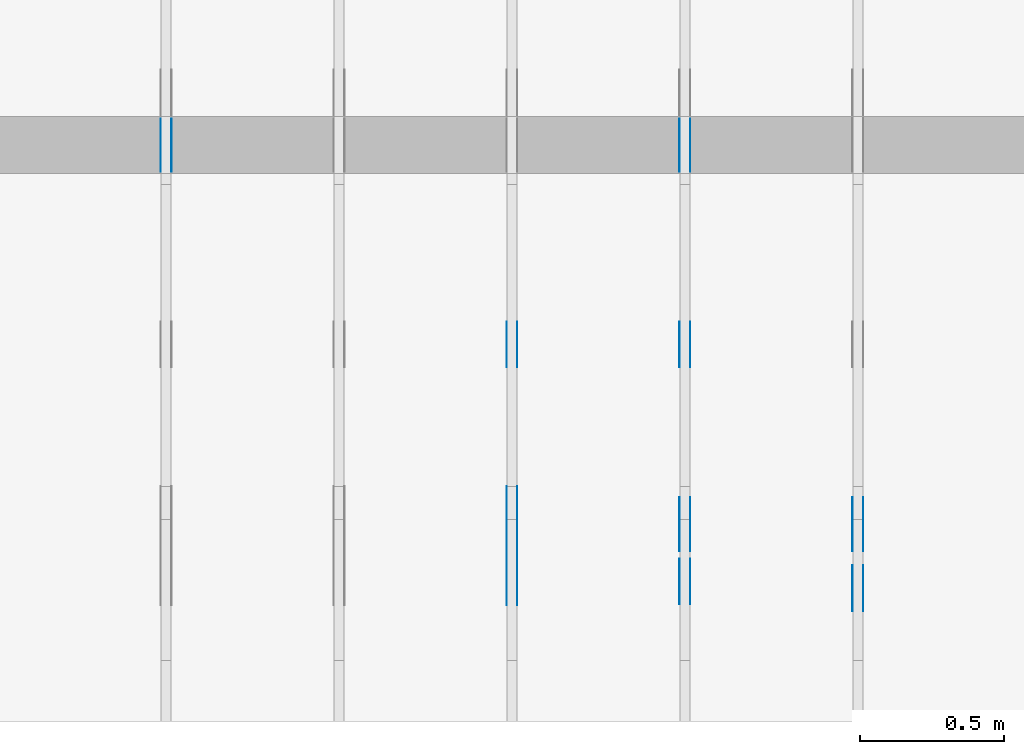
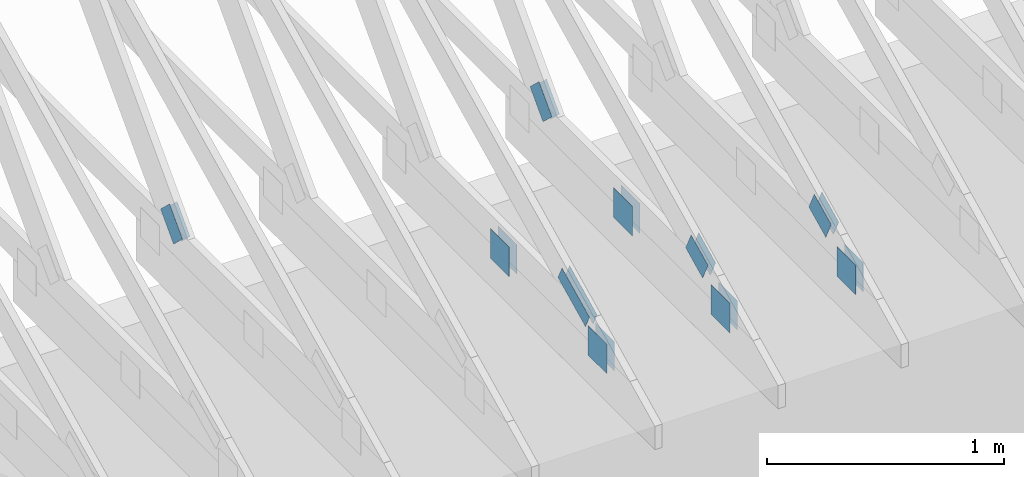
# One storey, part 74 of 159: 20 plates, 4 elements without a shape of their own.
"""IFC2X3 building model written with IfcOpenShell, lengths in millimetres."""

from ifc_helpers import new_model, si_unit, frame, origin, origin_with_axes, origin_2d, place, context, project, spatial, faceted_brep, element, aggregate, save


model = new_model("IFC2X3")

# Units and contexts
model_context = context("Model", 3, precision=1e-05, world=origin())
plan_context = context("Plan", 2, precision=1e-05, world=origin_2d())
ifc_project = project(units=[si_unit("LENGTHUNIT", "METRE", prefix="MILLI"), si_unit("AREAUNIT", "SQUARE_METRE"), si_unit("VOLUMEUNIT", "CUBIC_METRE"), si_unit("SOLIDANGLEUNIT", "STERADIAN"), si_unit("PLANEANGLEUNIT", "RADIAN"), si_unit("MASSUNIT", "GRAM"), si_unit("TIMEUNIT", "SECOND"), si_unit("THERMODYNAMICTEMPERATUREUNIT", "DEGREE_CELSIUS"), si_unit("LUMINOUSINTENSITYUNIT", "LUMEN")], contexts=[model_context, plan_context])

# Site, building, storey
site_placement = place(None, origin_with_axes())
site = spatial("IfcSite", under=ifc_project, at=site_placement, CompositionType="ELEMENT")
building_placement = place(site_placement, origin_with_axes())
building = spatial("IfcBuilding", under=site, at=building_placement, Name="Plan 1", CompositionType="ELEMENT")
storey_placement = place(building_placement, origin_with_axes())
storey = spatial("IfcBuildingStorey", under=building, at=storey_placement, Name="Etasje 1", CompositionType="ELEMENT", Elevation=0.0)

# Assembly, plates
assembly_1_placement = place(storey_placement, frame((10875.02226140475, -699.9989301294845, 1.1021457184401395e-15), z_axis=(-1.0, 1.836909530733566e-16, 6.123031769111886e-17), x_axis=(-1.836909530733566e-16, -1.0, 0.0)))
assembly_1 = element("IfcElementAssembly", 1, at=assembly_1_placement, inside=storey, Name="T4 (96)", AssemblyPlace="FACTORY", PredefinedType="TRUSS")
plate_1_placement = place(assembly_1_placement, frame((-589.402753917706, 382.43738721467554, 0.0), z_axis=(0.0, 0.0, 1.0), x_axis=(-0.898794046299167, 0.4383711467890773, 0.0)))
plate_1 = element("IfcPlate", 2, at=plate_1_placement, Name="GNT100S 103x159", context=model_context, shape_type="Brep", body=[
    faceted_brep([(159.00002333806833, 103.0000025629542, 1.0), (1.0586713528937253e-05, 103.0000025629542, 1.0), (1.127968232594867e-05, 1.5831964333301585e-05, 1.0), (159.00002403103713, 1.5831964333301585e-05, 1.0), (1.0586713528937253e-05, 103.0000025629542, 1.2964556653633881e-21), (159.00002333806833, 103.0000025629542, 1.9471243883770476e-14), (159.00002403103713, 1.4321251114779443e-05, 1.9471243968631875e-14), (1.127968232594867e-05, 1.4321251114779443e-05, 1.3813170645454712e-21), (159.0000000000001, -2.9206861538663717e-14, 5.268886006269513e-30), (159.0000000000001, -2.91456312209726e-14, 1.0), (1.1247455413666031e-32, 6.123031769111886e-17, 1.0), (0.0, 0.0, 0.0), (159.0000000000001, 103.00000000000006, 6.310887241768095e-30), (159.0000000000001, 103.00000000000006, 1.0), (159.0000000000001, 5.684341886080802e-14, 1.0), (159.0000000000001, 5.684341886080802e-14, 0.0), (0.0, 103.0, 0.0), (0.0, 103.0, 1.0), (159.0, 103.00000000000006, 1.0), (159.0, 103.00000000000006, 7.888609052210118e-31), (0.0, 0.0, 0.0), (6.123031769111886e-17, -7.498303609110687e-33, 1.0), (1.2674675762061605e-14, 103.0, 1.0), (1.2613445444370486e-14, 103.0, -7.723252717384008e-31)], [[[0, 1, 2, 3]], [[4, 5, 6, 7]], [[8, 9, 10, 11]], [[12, 13, 14, 15]], [[16, 17, 18, 19]], [[20, 21, 22, 23]]]),
])
plate_2_placement = place(assembly_1_placement, frame((-589.402753917706, 382.43738721467554, -37.0), z_axis=(0.0, 0.0, 1.0), x_axis=(-0.898794046299167, 0.4383711467890773, 0.0)))
plate_2 = element("IfcPlate", 3, at=plate_2_placement, Name="GNT100S 103x159", context=model_context, shape_type="Brep", body=[
    faceted_brep([(159.00002333806833, 103.0000025629542, 1.0), (1.0586713528937253e-05, 103.0000025629542, 1.0), (1.127968232594867e-05, 1.5831964333301585e-05, 1.0), (159.00002403103713, 1.5831964333301585e-05, 1.0), (1.0586713528937253e-05, 103.0000025629542, 1.2964556653633881e-21), (159.00002333806833, 103.0000025629542, 1.9471243883770476e-14), (159.00002403103713, 1.4321251114779443e-05, 1.9471243968631875e-14), (1.127968232594867e-05, 1.4321251114779443e-05, 1.3813170645454712e-21), (159.0000000000001, -2.9206861538663717e-14, 5.268886006269513e-30), (159.0000000000001, -2.91456312209726e-14, 1.0), (1.1247455413666031e-32, 6.123031769111886e-17, 1.0), (0.0, 0.0, 0.0), (159.0000000000001, 103.00000000000006, 6.310887241768095e-30), (159.0000000000001, 103.00000000000006, 1.0), (159.0000000000001, 5.684341886080802e-14, 1.0), (159.0000000000001, 5.684341886080802e-14, 0.0), (0.0, 103.0, 0.0), (0.0, 103.0, 1.0), (159.0, 103.00000000000006, 1.0), (159.0, 103.00000000000006, 7.888609052210118e-31), (0.0, 0.0, 0.0), (6.123031769111886e-17, -7.498303609110687e-33, 1.0), (1.2674675762061605e-14, 103.0, 1.0), (1.2613445444370486e-14, 103.0, -7.723252717384008e-31)], [[[0, 1, 2, 3]], [[4, 5, 6, 7]], [[8, 9, 10, 11]], [[12, 13, 14, 15]], [[16, 17, 18, 19]], [[20, 21, 22, 23]]]),
])
plate_3_placement = place(assembly_1_placement, frame((-382.4755138126829, 299.0, 0.0), z_axis=(0.0, 0.0, 1.0), x_axis=(-1.0, 1.2246063538223773e-16, 0.0)))
plate_3 = element("IfcPlate", 4, at=plate_3_placement, Name="GNT100S 152x159", context=model_context, shape_type="Brep", body=[
    faceted_brep([(159.0000110896608, 152.0, 1.0), (1.1089660802099388e-05, 152.0, 1.0), (1.1089660858942807e-05, 0.0, 1.0), (159.0000110896608, 0.0, 1.0), (1.1089660802099388e-05, 152.0, 1.3580469079985871e-21), (159.0000110896608, 152.0, 1.9471242383822708e-14), (159.0000110896608, 0.0, 1.9471242383822708e-14), (1.1089660858942807e-05, 0.0, 1.3580469149596683e-21), (159.0, 8.447997618295233e-14, 1.788345410772899e-30), (159.0, 8.454120650064345e-14, 1.0), (5.684341886080802e-14, 1.1374806803930715e-13, 1.0), (5.684341886080802e-14, 1.1368683772161602e-13, 0.0), (159.0, 152.0000000000001, 0.0), (159.0, 152.0000000000001, 1.0), (159.0, 1.1368683772161603e-13, 1.0), (159.0, 1.1368683772161603e-13, 0.0), (4.861730685829017e-63, 152.0000000000001, 0.0), (-3.7491518045553436e-33, 152.0000000000001, 1.0), (159.0, 152.0000000000001, 1.0), (159.0, 152.0000000000001, 0.0), (5.684341886080802e-14, 1.1368683772161603e-13, 0.0), (5.690464917849913e-14, 1.1368683772161603e-13, 1.0), (8.01710585938975e-15, 152.0000000000001, 1.0), (7.955875541698632e-15, 152.0000000000001, -4.871407869292096e-31)], [[[0, 1, 2, 3]], [[4, 5, 6, 7]], [[8, 9, 10, 11]], [[12, 13, 14, 15]], [[16, 17, 18, 19]], [[20, 21, 22, 23]]]),
])
plate_4_placement = place(assembly_1_placement, frame((-382.4755138126829, 299.0, -37.0), z_axis=(0.0, 0.0, 1.0), x_axis=(-1.0, 1.2246063538223773e-16, 0.0)))
plate_4 = element("IfcPlate", 5, at=plate_4_placement, Name="GNT100S 152x159", context=model_context, shape_type="Brep", body=[
    faceted_brep([(159.0000110896608, 152.0, 1.0), (1.1089660802099388e-05, 152.0, 1.0), (1.1089660858942807e-05, 0.0, 1.0), (159.0000110896608, 0.0, 1.0), (1.1089660802099388e-05, 152.0, 1.3580469079985871e-21), (159.0000110896608, 152.0, 1.9471242383822708e-14), (159.0000110896608, 0.0, 1.9471242383822708e-14), (1.1089660858942807e-05, 0.0, 1.3580469149596683e-21), (159.0, 8.447997618295233e-14, 1.788345410772899e-30), (159.0, 8.454120650064345e-14, 1.0), (5.684341886080802e-14, 1.1374806803930715e-13, 1.0), (5.684341886080802e-14, 1.1368683772161602e-13, 0.0), (159.0, 152.0000000000001, 0.0), (159.0, 152.0000000000001, 1.0), (159.0, 1.1368683772161603e-13, 1.0), (159.0, 1.1368683772161603e-13, 0.0), (4.861730685829017e-63, 152.0000000000001, 0.0), (-3.7491518045553436e-33, 152.0000000000001, 1.0), (159.0, 152.0000000000001, 1.0), (159.0, 152.0000000000001, 0.0), (5.684341886080802e-14, 1.1368683772161603e-13, 0.0), (5.690464917849913e-14, 1.1368683772161603e-13, 1.0), (8.01710585938975e-15, 152.0000000000001, 1.0), (7.955875541698632e-15, 152.0000000000001, -4.871407869292096e-31)], [[[0, 1, 2, 3]], [[4, 5, 6, 7]], [[8, 9, 10, 11]], [[12, 13, 14, 15]], [[16, 17, 18, 19]], [[20, 21, 22, 23]]]),
])
aggregate(assembly_1, [plate_1, plate_2, plate_3, plate_4])

assembly_2_placement = place(storey_placement, frame((10275.02226140475, -699.9989301294845, 1.1021457184401395e-15), z_axis=(-1.0, 1.836909530733566e-16, 6.123031769111886e-17), x_axis=(-1.836909530733566e-16, -1.0, 0.0)))
assembly_2 = element("IfcElementAssembly", 6, at=assembly_2_placement, inside=storey, Name="T3 (95)", AssemblyPlace="FACTORY", PredefinedType="TRUSS")
plate_5_placement = place(assembly_2_placement, frame((-589.402753917706, 382.43738721467537, 0.0), z_axis=(0.0, 0.0, 1.0), x_axis=(-0.898794046299167, 0.4383711467890773, 0.0)))
plate_5 = element("IfcPlate", 7, at=plate_5_placement, Name="GNT100S 103x159", context=model_context, shape_type="Brep", body=[
    faceted_brep([(159.00002333806833, 103.00000256295402, 1.0), (1.0586713528937253e-05, 103.00000256295402, 1.0), (1.127968232594867e-05, 1.5831964162771328e-05, 1.0), (159.00002403103713, 1.5831964162771328e-05, 1.0), (1.0586713528937253e-05, 103.00000256295402, 1.2964556653633881e-21), (159.00002333806833, 103.00000256295402, 1.9471243883770476e-14), (159.00002403103713, 1.4321250944249186e-05, 1.9471243968631875e-14), (1.127968232594867e-05, 1.4321250944249186e-05, 1.3813170645454712e-21), (159.0, -2.92068615386637e-14, 1.788345410772899e-30), (159.0, -2.914563122097258e-14, 1.0), (1.1247455413666031e-32, 6.123031769111886e-17, 1.0), (0.0, 0.0, 0.0), (159.0, 103.0, 6.310887241768095e-30), (159.0, 103.0, 1.0), (159.0, 0.0, 1.0), (159.0, 0.0, 0.0), (0.0, 103.0, 0.0), (-3.7491518045553436e-33, 103.0, 1.0), (158.9999999999999, 102.99999999999999, 1.0), (158.9999999999999, 102.99999999999999, -7.888609052210118e-31), (0.0, 0.0, 0.0), (6.123031769111886e-17, -7.498303609110687e-33, 1.0), (1.2674675762061605e-14, 103.0, 1.0), (1.2613445444370486e-14, 103.0, -7.723252717384008e-31)], [[[0, 1, 2, 3]], [[4, 5, 6, 7]], [[8, 9, 10, 11]], [[12, 13, 14, 15]], [[16, 17, 18, 19]], [[20, 21, 22, 23]]]),
])
plate_6_placement = place(assembly_2_placement, frame((-589.402753917706, 382.43738721467537, -37.0), z_axis=(0.0, 0.0, 1.0), x_axis=(-0.898794046299167, 0.4383711467890773, 0.0)))
plate_6 = element("IfcPlate", 8, at=plate_6_placement, Name="GNT100S 103x159", context=model_context, shape_type="Brep", body=[
    faceted_brep([(159.00002333806833, 103.00000256295402, 1.0), (1.0586713528937253e-05, 103.00000256295402, 1.0), (1.127968232594867e-05, 1.5831964162771328e-05, 1.0), (159.00002403103713, 1.5831964162771328e-05, 1.0), (1.0586713528937253e-05, 103.00000256295402, 1.2964556653633881e-21), (159.00002333806833, 103.00000256295402, 1.9471243883770476e-14), (159.00002403103713, 1.4321250944249186e-05, 1.9471243968631875e-14), (1.127968232594867e-05, 1.4321250944249186e-05, 1.3813170645454712e-21), (159.0, -2.92068615386637e-14, 1.788345410772899e-30), (159.0, -2.914563122097258e-14, 1.0), (1.1247455413666031e-32, 6.123031769111886e-17, 1.0), (0.0, 0.0, 0.0), (159.0, 103.0, 6.310887241768095e-30), (159.0, 103.0, 1.0), (159.0, 0.0, 1.0), (159.0, 0.0, 0.0), (0.0, 103.0, 0.0), (-3.7491518045553436e-33, 103.0, 1.0), (158.9999999999999, 102.99999999999999, 1.0), (158.9999999999999, 102.99999999999999, -7.888609052210118e-31), (0.0, 0.0, 0.0), (6.123031769111886e-17, -7.498303609110687e-33, 1.0), (1.2674675762061605e-14, 103.0, 1.0), (1.2613445444370486e-14, 103.0, -7.723252717384008e-31)], [[[0, 1, 2, 3]], [[4, 5, 6, 7]], [[8, 9, 10, 11]], [[12, 13, 14, 15]], [[16, 17, 18, 19]], [[20, 21, 22, 23]]]),
])
plate_7_placement = place(assembly_2_placement, frame((-1386.851318359375, 147.0, 0.0), z_axis=(0.0, 0.0, 1.0), x_axis=(1.0, 0.0, 0.0)))
plate_7 = element("IfcPlate", 9, at=plate_7_placement, Name="GNT100S 152x159", context=model_context, shape_type="Brep", body=[
    faceted_brep([(159.0, 152.0, 1.0), (0.0, 152.0, 1.0), (0.0, 0.0, 1.0), (159.0, 0.0, 1.0), (0.0, 152.0, 0.0), (159.0, 152.0, 1.9471241025775798e-14), (159.0, 0.0, 1.9471241025775798e-14), (0.0, 0.0, 0.0), (159.0000360627621, 1.1290167898895321e-13, 1.7883458163872074e-30), (159.0000360627621, 1.1296290930664433e-13, 1.0), (3.606276209211501e-05, 1.4216977084530802e-13, 1.0), (3.606276209211501e-05, 1.421085405276169e-13, 4.056143085454382e-37), (159.0000360627621, 152.0000000000001, 0.0), (159.0000360627621, 152.0000000000001, 1.0), (159.0000360627621, 1.4210854715202004e-13, 1.0), (159.0000360627621, 1.4210854715202004e-13, 0.0), (3.606276209211501e-05, 152.0000000000001, 0.0), (3.606276209211501e-05, 152.0000000000001, 1.0), (159.0000360627621, 152.0000000000001, 1.0), (159.0000360627621, 152.0000000000001, 0.0), (3.606276209211501e-05, 1.4210854715202004e-13, 0.0), (3.606276209217624e-05, 1.4210854715202004e-13, 1.0), (3.6062762110790255e-05, 152.0000000000001, 1.0), (3.6062762110729025e-05, 152.0000000000001, -1.1397420192804459e-30)], [[[0, 1, 2, 3]], [[4, 5, 6, 7]], [[8, 9, 10, 11]], [[12, 13, 14, 15]], [[16, 17, 18, 19]], [[20, 21, 22, 23]]]),
])
plate_8_placement = place(assembly_2_placement, frame((-1386.851318359375, 147.0, -37.0), z_axis=(0.0, 0.0, 1.0), x_axis=(1.0, 0.0, 0.0)))
plate_8 = element("IfcPlate", 10, at=plate_8_placement, Name="GNT100S 152x159", context=model_context, shape_type="Brep", body=[
    faceted_brep([(159.0, 152.0, 1.0), (0.0, 152.0, 1.0), (0.0, 0.0, 1.0), (159.0, 0.0, 1.0), (0.0, 152.0, 0.0), (159.0, 152.0, 1.9471241025775798e-14), (159.0, 0.0, 1.9471241025775798e-14), (0.0, 0.0, 0.0), (159.0000360627621, 1.1290167898895321e-13, 1.7883458163872074e-30), (159.0000360627621, 1.1296290930664433e-13, 1.0), (3.606276209211501e-05, 1.4216977084530802e-13, 1.0), (3.606276209211501e-05, 1.421085405276169e-13, 4.056143085454382e-37), (159.0000360627621, 152.0000000000001, 0.0), (159.0000360627621, 152.0000000000001, 1.0), (159.0000360627621, 1.4210854715202004e-13, 1.0), (159.0000360627621, 1.4210854715202004e-13, 0.0), (3.606276209211501e-05, 152.0000000000001, 0.0), (3.606276209211501e-05, 152.0000000000001, 1.0), (159.0000360627621, 152.0000000000001, 1.0), (159.0000360627621, 152.0000000000001, 0.0), (3.606276209211501e-05, 1.4210854715202004e-13, 0.0), (3.606276209217624e-05, 1.4210854715202004e-13, 1.0), (3.6062762110790255e-05, 152.0000000000001, 1.0), (3.6062762110729025e-05, 152.0000000000001, -1.1397420192804459e-30)], [[[0, 1, 2, 3]], [[4, 5, 6, 7]], [[8, 9, 10, 11]], [[12, 13, 14, 15]], [[16, 17, 18, 19]], [[20, 21, 22, 23]]]),
])
plate_9_placement = place(assembly_2_placement, frame((-405.45207631197576, 299.0000000000001, 0.0), z_axis=(0.0, 0.0, 1.0), x_axis=(-1.0, 1.2246063538223773e-16, 0.0)))
plate_9 = element("IfcPlate", 11, at=plate_9_placement, Name="GNT100S 152x159", context=model_context, shape_type="Brep", body=[
    faceted_brep([(159.00001109036793, 152.0000000000001, 1.0), (1.1090367934230017e-05, 152.0000000000001, 1.0), (1.1090367991073435e-05, 1.1368683772161603e-13, 1.0), (159.00001109036793, 1.1368683772161603e-13, 1.0), (1.1090367934230017e-05, 152.0000000000001, 1.358133503848603e-21), (159.00001109036793, 152.0000000000001, 1.9471242383909303e-14), (159.00001109036793, 1.1368683772161603e-13, 1.9471242383909303e-14), (1.1090367991073435e-05, 1.1368683772161603e-13, 1.3581335108096843e-21), (159.0, -2.92068615386637e-14, 1.788345410772899e-30), (159.0, -2.914563122097258e-14, 1.0), (5.684341886080802e-14, 6.123031769110842e-17, 1.0), (5.684341886080802e-14, -1.0441621786489838e-29, 6.393438191972809e-46), (159.0, 152.0, 0.0), (159.0, 152.0, 1.0), (159.0, 0.0, 1.0), (159.0, 0.0, 0.0), (0.0, 152.0, 0.0), (-3.7491518045553436e-33, 152.0, 1.0), (159.0, 152.0, 1.0), (159.0, 152.0, 0.0), (5.684341886080802e-14, 0.0, 0.0), (5.690464917849913e-14, 1.96934197932066e-32, 1.0), (8.01710585938975e-15, 152.0, 1.0), (7.955875541698632e-15, 152.0, -4.871407869292096e-31)], [[[0, 1, 2, 3]], [[4, 5, 6, 7]], [[8, 9, 10, 11]], [[12, 13, 14, 15]], [[16, 17, 18, 19]], [[20, 21, 22, 23]]]),
])
plate_10_placement = place(assembly_2_placement, frame((-405.45207631197576, 299.0000000000001, -37.0), z_axis=(0.0, 0.0, 1.0), x_axis=(-1.0, 1.2246063538223773e-16, 0.0)))
plate_10 = element("IfcPlate", 12, at=plate_10_placement, Name="GNT100S 152x159", context=model_context, shape_type="Brep", body=[
    faceted_brep([(159.00001109036793, 152.0000000000001, 1.0), (1.1090367934230017e-05, 152.0000000000001, 1.0), (1.1090367991073435e-05, 1.1368683772161603e-13, 1.0), (159.00001109036793, 1.1368683772161603e-13, 1.0), (1.1090367934230017e-05, 152.0000000000001, 1.358133503848603e-21), (159.00001109036793, 152.0000000000001, 1.9471242383909303e-14), (159.00001109036793, 1.1368683772161603e-13, 1.9471242383909303e-14), (1.1090367991073435e-05, 1.1368683772161603e-13, 1.3581335108096843e-21), (159.0, -2.92068615386637e-14, 1.788345410772899e-30), (159.0, -2.914563122097258e-14, 1.0), (5.684341886080802e-14, 6.123031769110842e-17, 1.0), (5.684341886080802e-14, -1.0441621786489838e-29, 6.393438191972809e-46), (159.0, 152.0, 0.0), (159.0, 152.0, 1.0), (159.0, 0.0, 1.0), (159.0, 0.0, 0.0), (0.0, 152.0, 0.0), (-3.7491518045553436e-33, 152.0, 1.0), (159.0, 152.0, 1.0), (159.0, 152.0, 0.0), (5.684341886080802e-14, 0.0, 0.0), (5.690464917849913e-14, 1.96934197932066e-32, 1.0), (8.01710585938975e-15, 152.0, 1.0), (7.955875541698632e-15, 152.0, -4.871407869292096e-31)], [[[0, 1, 2, 3]], [[4, 5, 6, 7]], [[8, 9, 10, 11]], [[12, 13, 14, 15]], [[16, 17, 18, 19]], [[20, 21, 22, 23]]]),
])
plate_11_placement = place(assembly_2_placement, frame((-1906.8051272433, 348.9325207789061, 0.0), z_axis=(0.0, 0.0, 1.0), x_axis=(-0.6895311389667145, 0.7242560378728407, 0.0)))
plate_11 = element("IfcPlate", 13, at=plate_11_placement, Name="GNT100S 103x159", context=model_context, shape_type="Brep", body=[
    faceted_brep([(159.00006393254853, 103.00005857159113, 1.0), (3.3193706258316524e-05, 103.00005857159113, 1.0), (1.4882773484714562e-05, 5.2848457471554866e-05, 1.0), (158.99996145033424, 5.2848457471554866e-05, 1.0), (3.3193706258316524e-05, 103.00005857159113, 4.0649223590848024e-21), (159.00006393254853, 103.00005857159113, 1.9471248854996312e-14), (158.99996145033424, 0.0, 1.9471236304959237e-14), (1.4882773484714562e-05, 0.0, 1.8225538971880656e-21), (159.0, 3.209863868313434e-05, 1.788345571668688e-30), (159.0, 3.209863868319557e-05, 1.0), (2.2737367544323206e-13, 3.209863871240243e-05, 1.0), (2.2737367544323206e-13, 3.20986387123412e-05, 0.0), (159.0, 103.00003209863894, 0.0), (159.0, 103.00003209863894, 1.0), (159.0, 3.20986387123412e-05, 1.0), (159.0, 3.20986387123412e-05, 0.0), (0.0, 103.00003209863871, 0.0), (0.0, 103.00003209863871, 1.0), (159.0, 103.00003209863895, 1.0), (159.0, 103.00003209863895, 7.888609052210118e-31), (2.2737366470420837e-13, 3.20986387123412e-05, 6.575538337152157e-37), (2.2743489502189947e-13, 3.20986387123412e-05, 1.0), (-3.4398791221068746e-14, 103.00003209863871, 1.0), (-3.4460021538759865e-14, 103.00003209863871, 2.1099980664610653e-30)], [[[0, 1, 2, 3]], [[4, 5, 6, 7]], [[8, 9, 10, 11]], [[12, 13, 14, 15]], [[16, 17, 18, 19]], [[20, 21, 22, 23]]]),
])
plate_12_placement = place(assembly_2_placement, frame((-1906.8051272433, 348.9325207789061, -37.0), z_axis=(0.0, 0.0, 1.0), x_axis=(-0.6895311389667145, 0.7242560378728407, 0.0)))
plate_12 = element("IfcPlate", 14, at=plate_12_placement, Name="GNT100S 103x159", context=model_context, shape_type="Brep", body=[
    faceted_brep([(159.00006393254853, 103.00005857159113, 1.0), (3.3193706258316524e-05, 103.00005857159113, 1.0), (1.4882773484714562e-05, 5.2848457471554866e-05, 1.0), (158.99996145033424, 5.2848457471554866e-05, 1.0), (3.3193706258316524e-05, 103.00005857159113, 4.0649223590848024e-21), (159.00006393254853, 103.00005857159113, 1.9471248854996312e-14), (158.99996145033424, 0.0, 1.9471236304959237e-14), (1.4882773484714562e-05, 0.0, 1.8225538971880656e-21), (159.0, 3.209863868313434e-05, 1.788345571668688e-30), (159.0, 3.209863868319557e-05, 1.0), (2.2737367544323206e-13, 3.209863871240243e-05, 1.0), (2.2737367544323206e-13, 3.20986387123412e-05, 0.0), (159.0, 103.00003209863894, 0.0), (159.0, 103.00003209863894, 1.0), (159.0, 3.20986387123412e-05, 1.0), (159.0, 3.20986387123412e-05, 0.0), (0.0, 103.00003209863871, 0.0), (0.0, 103.00003209863871, 1.0), (159.0, 103.00003209863895, 1.0), (159.0, 103.00003209863895, 7.888609052210118e-31), (2.2737366470420837e-13, 3.20986387123412e-05, 6.575538337152157e-37), (2.2743489502189947e-13, 3.20986387123412e-05, 1.0), (-3.4398791221068746e-14, 103.00003209863871, 1.0), (-3.4460021538759865e-14, 103.00003209863871, 2.1099980664610653e-30)], [[[0, 1, 2, 3]], [[4, 5, 6, 7]], [[8, 9, 10, 11]], [[12, 13, 14, 15]], [[16, 17, 18, 19]], [[20, 21, 22, 23]]]),
])
aggregate(assembly_2, [plate_5, plate_6, plate_7, plate_8, plate_9, plate_10, plate_11, plate_12])

assembly_3_placement = place(storey_placement, frame((9675.022261404752, 9699.99999999999, 1.1021457184401395e-15), z_axis=(-1.0, 1.836909530733566e-16, 6.123031769111886e-17), x_axis=(-1.836909530733566e-16, -1.0, 0.0)))
assembly_3 = element("IfcElementAssembly", 15, at=assembly_3_placement, inside=storey, Name="T2 (94)", AssemblyPlace="FACTORY", PredefinedType="TRUSS")
plate_13_placement = place(assembly_3_placement, frame((9849.1689453125, 348.6043090820308, 0.0), z_axis=(0.0, 0.0, 1.0), x_axis=(-0.898794046299167, 0.4383711467890773, 0.0)))
plate_13 = element("IfcPlate", 16, at=plate_13_placement, Name="GNT100S 76x258", context=model_context, shape_type="Brep", body=[
    faceted_brep([(257.99999468874375, 76.00008915613216, 1.0), (0.00017802805450628512, 76.00008915613216, 1.0), (0.0, 0.0, 1.0), (258.0006943892513, 0.0, 1.0), (0.00017802805450628512, 76.00008915613216, 2.1801428670703325e-20), (257.99999468874375, 76.00008915613216, 3.1594843278197516e-14), (258.0006943892513, 0.0003658529813037603, 3.159492896396625e-14), (0.0, 0.0003658529813037603, 0.0), (258.0004204757515, 0.0002198311096505291, -1.1564171119434705e-29), (258.0004204757515, 0.00021983110965059034, 1.0), (0.0004204757515253732, 0.00021983110855223245, 1.0), (0.0004204757515253732, 0.00021983110855217122, -1.8055593228630336e-35), (258.0004204757515, 76.00021983110946, 0.0), (258.0004204757515, 76.00021983110946, 1.0), (258.0004204757515, 0.00021983110946166562, 1.0), (258.0004204757515, 0.00021983110946166562, 0.0), (0.0004204757515253732, 76.00021983110855, 0.0), (0.0004204757515253732, 76.00021983110855, 1.0), (258.0004204757515, 76.00021983110945, 1.0), (258.0004204757515, 76.00021983110945, -7.888609052210118e-31), (0.0004204757515253732, 0.00021983110855217092, -3.009265538105056e-36), (0.00042047575152543446, 0.00021983110855217092, 1.0), (0.00042047575153474146, 76.00021983110855, 1.0), (0.0004204757515346802, 76.00021983110855, -5.698736427475688e-31)], [[[0, 1, 2, 3]], [[4, 5, 6, 7]], [[8, 9, 10, 11]], [[12, 13, 14, 15]], [[16, 17, 18, 19]], [[20, 21, 22, 23]]]),
])
plate_14_placement = place(assembly_3_placement, frame((9849.1689453125, 348.6043090820308, -37.0), z_axis=(0.0, 0.0, 1.0), x_axis=(-0.898794046299167, 0.4383711467890773, 0.0)))
plate_14 = element("IfcPlate", 17, at=plate_14_placement, Name="GNT100S 76x258", context=model_context, shape_type="Brep", body=[
    faceted_brep([(257.99999468874375, 76.00008915613216, 1.0), (0.00017802805450628512, 76.00008915613216, 1.0), (0.0, 0.0, 1.0), (258.0006943892513, 0.0, 1.0), (0.00017802805450628512, 76.00008915613216, 2.1801428670703325e-20), (257.99999468874375, 76.00008915613216, 3.1594843278197516e-14), (258.0006943892513, 0.0003658529813037603, 3.159492896396625e-14), (0.0, 0.0003658529813037603, 0.0), (258.0004204757515, 0.0002198311096505291, -1.1564171119434705e-29), (258.0004204757515, 0.00021983110965059034, 1.0), (0.0004204757515253732, 0.00021983110855223245, 1.0), (0.0004204757515253732, 0.00021983110855217122, -1.8055593228630336e-35), (258.0004204757515, 76.00021983110946, 0.0), (258.0004204757515, 76.00021983110946, 1.0), (258.0004204757515, 0.00021983110946166562, 1.0), (258.0004204757515, 0.00021983110946166562, 0.0), (0.0004204757515253732, 76.00021983110855, 0.0), (0.0004204757515253732, 76.00021983110855, 1.0), (258.0004204757515, 76.00021983110945, 1.0), (258.0004204757515, 76.00021983110945, -7.888609052210118e-31), (0.0004204757515253732, 0.00021983110855217092, -3.009265538105056e-36), (0.00042047575152543446, 0.00021983110855217092, 1.0), (0.00042047575153474146, 76.00021983110855, 1.0), (0.0004204757515346802, 76.00021983110855, -5.698736427475688e-31)], [[[0, 1, 2, 3]], [[4, 5, 6, 7]], [[8, 9, 10, 11]], [[12, 13, 14, 15]], [[16, 17, 18, 19]], [[20, 21, 22, 23]]]),
])
plate_15_placement = place(assembly_3_placement, frame((9172.147647832993, 299.0, 0.0), z_axis=(0.0, 0.0, 1.0), x_axis=(-1.0, 1.2246063538223773e-16, 0.0)))
plate_15 = element("IfcPlate", 18, at=plate_15_placement, Name="GNT100S 152x159", context=model_context, shape_type="Brep", body=[
    faceted_brep([(159.00018689549324, 152.0, 1.0), (0.0001868954932433553, 152.0, 1.0), (0.0001868954932433553, 0.0, 1.0), (159.00018689549324, 0.0, 1.0), (0.0001868954932433553, 152.0, 2.2887340852658008e-20), (159.00018689549324, 152.0, 1.947126391311665e-14), (159.00018689549324, 5.684341886080802e-14, 1.947126391311665e-14), (0.0001868954932433553, 5.684341886080802e-14, 2.2887340852658008e-20), (159.0, 1.4487220288423447e-12, 5.2688860062695115e-30), (159.0, 1.4487832591600358e-12, 1.0), (1.1247455413666031e-32, 1.4779901206986995e-12, 1.0), (0.0, 1.4779288903810084e-12, 0.0), (159.0, 152.0000000000015, 0.0), (159.0, 152.0000000000015, 1.0), (159.0, 1.5347723092418164e-12, 1.0), (159.0, 1.5347723092418164e-12, 0.0), (0.0, 152.00000000000148, 0.0), (0.0, 152.00000000000148, 1.0), (159.0, 152.0000000000015, 1.0), (159.0, 152.0000000000015, 0.0), (1.8098811096582386e-28, 1.4779288903810084e-12, -1.1081959532752868e-44), (6.123031769129986e-17, 1.4779288903810084e-12, 1.0), (1.8675246895791433e-14, 152.00000000000148, 1.0), (1.8614016578100314e-14, 152.00000000000148, -1.1397421485848355e-30)], [[[0, 1, 2, 3]], [[4, 5, 6, 7]], [[8, 9, 10, 11]], [[12, 13, 14, 15]], [[16, 17, 18, 19]], [[20, 21, 22, 23]]]),
])
plate_16_placement = place(assembly_3_placement, frame((9172.147647832993, 299.0, -37.0), z_axis=(0.0, 0.0, 1.0), x_axis=(-1.0, 1.2246063538223773e-16, 0.0)))
plate_16 = element("IfcPlate", 19, at=plate_16_placement, Name="GNT100S 152x159", context=model_context, shape_type="Brep", body=[
    faceted_brep([(159.00018689549324, 152.0, 1.0), (0.0001868954932433553, 152.0, 1.0), (0.0001868954932433553, 0.0, 1.0), (159.00018689549324, 0.0, 1.0), (0.0001868954932433553, 152.0, 2.2887340852658008e-20), (159.00018689549324, 152.0, 1.947126391311665e-14), (159.00018689549324, 5.684341886080802e-14, 1.947126391311665e-14), (0.0001868954932433553, 5.684341886080802e-14, 2.2887340852658008e-20), (159.0, 1.4487220288423447e-12, 5.2688860062695115e-30), (159.0, 1.4487832591600358e-12, 1.0), (1.1247455413666031e-32, 1.4779901206986995e-12, 1.0), (0.0, 1.4779288903810084e-12, 0.0), (159.0, 152.0000000000015, 0.0), (159.0, 152.0000000000015, 1.0), (159.0, 1.5347723092418164e-12, 1.0), (159.0, 1.5347723092418164e-12, 0.0), (0.0, 152.00000000000148, 0.0), (0.0, 152.00000000000148, 1.0), (159.0, 152.0000000000015, 1.0), (159.0, 152.0000000000015, 0.0), (1.8098811096582386e-28, 1.4779288903810084e-12, -1.1081959532752868e-44), (6.123031769129986e-17, 1.4779288903810084e-12, 1.0), (1.8675246895791433e-14, 152.00000000000148, 1.0), (1.8614016578100314e-14, 152.00000000000148, -1.1397421485848355e-30)], [[[0, 1, 2, 3]], [[4, 5, 6, 7]], [[8, 9, 10, 11]], [[12, 13, 14, 15]], [[16, 17, 18, 19]], [[20, 21, 22, 23]]]),
])
plate_17_placement = place(assembly_3_placement, frame((9997.207498348753, 299.0000000000001, 0.0), z_axis=(0.0, 0.0, 1.0), x_axis=(-1.0, 1.2246063538223773e-16, 0.0)))
plate_17 = element("IfcPlate", 20, at=plate_17_placement, Name="GNT100S 152x159", context=model_context, shape_type="Brep", body=[
    faceted_brep([(159.00046709875278, 152.00000000000014, 1.0), (0.0004670987527788384, 152.00000000000014, 1.0), (0.0004670987527788384, 1.1368683772161603e-13, 1.0), (159.00046709875278, 1.1368683772161603e-13, 1.0), (0.0004670987527788384, 152.00000000000014, 5.720121005154733e-20), (159.00046709875278, 152.00000000000014, 1.947129822698585e-14), (159.00046709875278, 1.7053025658242404e-13, 1.947129822698585e-14), (0.0004670987527788384, 1.7053025658242404e-13, 5.720121005154733e-20), (159.0, -2.92068615386637e-14, 5.2688860062695115e-30), (159.0, -2.914563122097258e-14, 1.0), (1.1247455413666031e-32, 6.123031769111886e-17, 1.0), (0.0, 0.0, 0.0), (159.0, 152.00000000000006, 0.0), (159.0, 152.00000000000006, 1.0), (159.0, 5.684341886080802e-14, 1.0), (159.0, 5.684341886080802e-14, 0.0), (0.0, 152.00000000000003, 0.0), (0.0, 152.00000000000003, 1.0), (159.0, 152.00000000000006, 1.0), (159.0, 152.00000000000006, 0.0), (0.0, 0.0, 0.0), (6.123031769111886e-17, -7.498303609110687e-33, 1.0), (1.8675246895791256e-14, 152.00000000000003, 1.0), (1.8614016578100137e-14, 152.00000000000003, -1.1397421485848246e-30)], [[[0, 1, 2, 3]], [[4, 5, 6, 7]], [[8, 9, 10, 11]], [[12, 13, 14, 15]], [[16, 17, 18, 19]], [[20, 21, 22, 23]]]),
])
plate_18_placement = place(assembly_3_placement, frame((9997.207498348753, 299.0000000000001, -37.0), z_axis=(0.0, 0.0, 1.0), x_axis=(-1.0, 1.2246063538223773e-16, 0.0)))
plate_18 = element("IfcPlate", 21, at=plate_18_placement, Name="GNT100S 152x159", context=model_context, shape_type="Brep", body=[
    faceted_brep([(159.00046709875278, 152.00000000000014, 1.0), (0.0004670987527788384, 152.00000000000014, 1.0), (0.0004670987527788384, 1.1368683772161603e-13, 1.0), (159.00046709875278, 1.1368683772161603e-13, 1.0), (0.0004670987527788384, 152.00000000000014, 5.720121005154733e-20), (159.00046709875278, 152.00000000000014, 1.947129822698585e-14), (159.00046709875278, 1.7053025658242404e-13, 1.947129822698585e-14), (0.0004670987527788384, 1.7053025658242404e-13, 5.720121005154733e-20), (159.0, -2.92068615386637e-14, 5.2688860062695115e-30), (159.0, -2.914563122097258e-14, 1.0), (1.1247455413666031e-32, 6.123031769111886e-17, 1.0), (0.0, 0.0, 0.0), (159.0, 152.00000000000006, 0.0), (159.0, 152.00000000000006, 1.0), (159.0, 5.684341886080802e-14, 1.0), (159.0, 5.684341886080802e-14, 0.0), (0.0, 152.00000000000003, 0.0), (0.0, 152.00000000000003, 1.0), (159.0, 152.00000000000006, 1.0), (159.0, 152.00000000000006, 0.0), (0.0, 0.0, 0.0), (6.123031769111886e-17, -7.498303609110687e-33, 1.0), (1.8675246895791256e-14, 152.00000000000003, 1.0), (1.8614016578100137e-14, 152.00000000000003, -1.1397421485848246e-30)], [[[0, 1, 2, 3]], [[4, 5, 6, 7]], [[8, 9, 10, 11]], [[12, 13, 14, 15]], [[16, 17, 18, 19]], [[20, 21, 22, 23]]]),
])
aggregate(assembly_3, [plate_13, plate_14, plate_15, plate_16, plate_17, plate_18])

assembly_4_placement = place(storey_placement, frame((8475.022261404752, 9699.99999999999, 1.1021457184401395e-15), z_axis=(-1.0, 1.836909530733566e-16, 6.123031769111886e-17), x_axis=(-1.836909530733566e-16, -1.0, 0.0)))
assembly_4 = element("IfcElementAssembly", 22, at=assembly_4_placement, inside=storey, Name="T2 (92)", AssemblyPlace="FACTORY", PredefinedType="TRUSS")
plate_19_placement = place(assembly_4_placement, frame((8493.194053413827, 348.9324838526172, 0.0), z_axis=(0.0, 0.0, 1.0), x_axis=(-0.6895311389452026, 0.724256037893321, 0.0)))
plate_19 = element("IfcPlate", 23, at=plate_19_placement, Name="GNT100S 103x159", context=model_context, shape_type="Brep", body=[
    faceted_brep([(159.0001990814053, 102.99997015670851, 1.0), (0.0, 102.99997015670851, 1.0), (0.0004867198158535757, 0.00049489453977003, 1.0), (159.00001243096904, 0.00049489453977003, 1.0), (0.0, 102.99997015670851, 0.0), (159.0001990814053, 102.99997015670851, 1.9471265405411186e-14), (159.00001243096904, 0.0, 1.9471242548080165e-14), (0.0004867198158535757, 0.0, 5.960401790255462e-20), (159.00019948917543, 0.00018808533965774285, 1.7883478286178417e-30), (159.00019948917543, 0.00018808533965780408, 1.0), (0.00019948917542933486, 0.00018808533968701094, 1.0), (0.00019948917542933486, 0.0001880853396869497, 1.504632769052528e-36), (159.00019948917543, 103.00018808533878, 5.522026336547083e-29), (159.00019948917543, 103.00018808533878, 1.0), (159.00019948917543, 0.00018808533968694974, 1.0), (159.00019948917543, 0.00018808533968694974, 0.0), (0.0001994891754293349, 103.00018808533969, 0.0), (0.0001994891754293349, 103.00018808533969, 1.0), (159.00019948917452, 103.00018808533883, 1.0), (159.00019948917452, 103.00018808533883, 2.3665827156630354e-30), (0.0001994891754293349, 0.00018808533968694974, -1.504632769052528e-36), (0.00019948917542939612, 0.00018808533968694974, 1.0), (0.00019948917544200957, 103.00018808533969, 1.0), (0.00019948917544194834, 103.00018808533969, -7.723264957218936e-31)], [[[0, 1, 2, 3]], [[4, 5, 6, 7]], [[8, 9, 10, 11]], [[12, 13, 14, 15]], [[16, 17, 18, 19]], [[20, 21, 22, 23]]]),
])
plate_20_placement = place(assembly_4_placement, frame((8493.194053413827, 348.9324838526172, -37.0), z_axis=(0.0, 0.0, 1.0), x_axis=(-0.6895311389452026, 0.724256037893321, 0.0)))
plate_20 = element("IfcPlate", 24, at=plate_20_placement, Name="GNT100S 103x159", context=model_context, shape_type="Brep", body=[
    faceted_brep([(159.0001990814053, 102.99997015670851, 1.0), (0.0, 102.99997015670851, 1.0), (0.0004867198158535757, 0.00049489453977003, 1.0), (159.00001243096904, 0.00049489453977003, 1.0), (0.0, 102.99997015670851, 0.0), (159.0001990814053, 102.99997015670851, 1.9471265405411186e-14), (159.00001243096904, 0.0, 1.9471242548080165e-14), (0.0004867198158535757, 0.0, 5.960401790255462e-20), (159.00019948917543, 0.00018808533965774285, 1.7883478286178417e-30), (159.00019948917543, 0.00018808533965780408, 1.0), (0.00019948917542933486, 0.00018808533968701094, 1.0), (0.00019948917542933486, 0.0001880853396869497, 1.504632769052528e-36), (159.00019948917543, 103.00018808533878, 5.522026336547083e-29), (159.00019948917543, 103.00018808533878, 1.0), (159.00019948917543, 0.00018808533968694974, 1.0), (159.00019948917543, 0.00018808533968694974, 0.0), (0.0001994891754293349, 103.00018808533969, 0.0), (0.0001994891754293349, 103.00018808533969, 1.0), (159.00019948917452, 103.00018808533883, 1.0), (159.00019948917452, 103.00018808533883, 2.3665827156630354e-30), (0.0001994891754293349, 0.00018808533968694974, -1.504632769052528e-36), (0.00019948917542939612, 0.00018808533968694974, 1.0), (0.00019948917544200957, 103.00018808533969, 1.0), (0.00019948917544194834, 103.00018808533969, -7.723264957218936e-31)], [[[0, 1, 2, 3]], [[4, 5, 6, 7]], [[8, 9, 10, 11]], [[12, 13, 14, 15]], [[16, 17, 18, 19]], [[20, 21, 22, 23]]]),
])
aggregate(assembly_4, [plate_19, plate_20])

save(model, "model.ifc")
